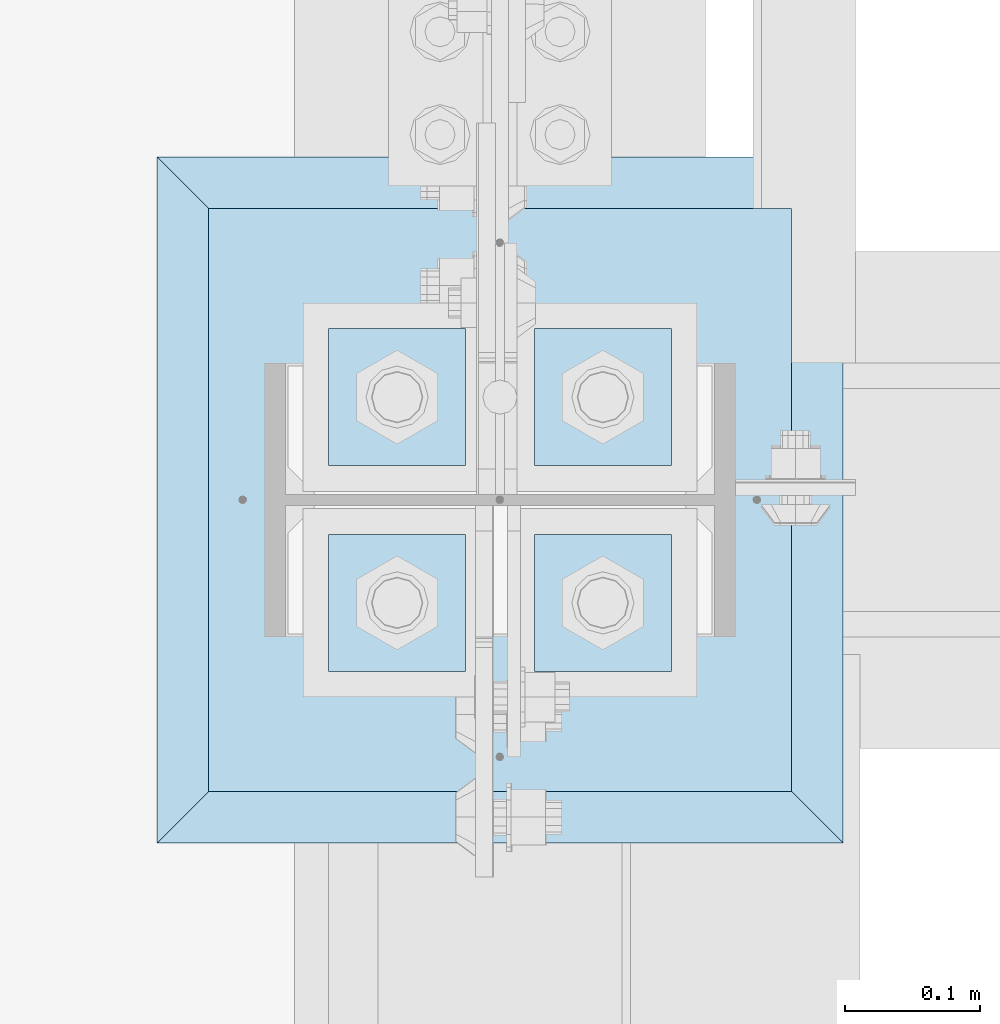
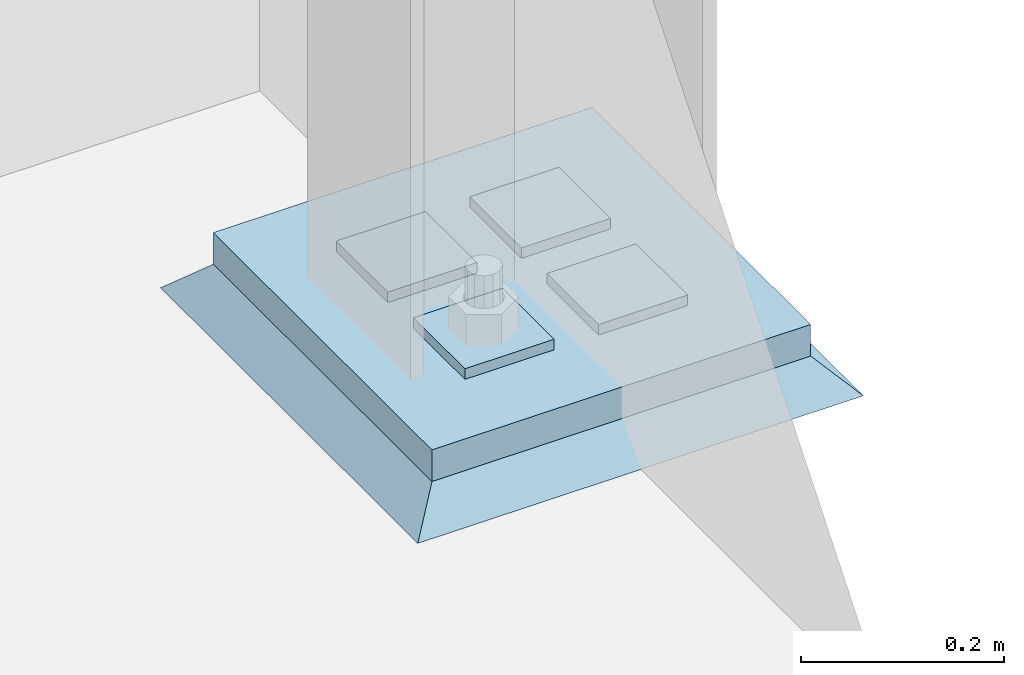
# One storey, part 3505 of 3843: 6 plates, 3 elements without a shape of their own.
"""IFC2X3 building model written with IfcOpenShell, lengths in millimetres."""

import ifcopenshell
import ifcopenshell.guid

model = None  # the IFC model being written
_history = None  # IfcOwnerHistory: only IFC2X3 demands one
_inside = {}  # id of a spatial element -> (the spatial element, [elements in it])
_under = {}  # id of a project, library or spatial element -> (it, [spatial elements below it])
_declared = {}  # id of a project -> (the project, [libraries it declares])
_typed = {}  # id of a type object -> (the type object, [elements of that type])
_made_of = {}  # id of a material, layer set ... -> (it, [elements and type objects made of it])


def new_model(schema):
    """Start an empty IFC model of exactly this schema.

    Asked for "IFC4X3", IfcOpenShell would pick the latest addendum, in which some entities
    have other attributes; the version numbers below select the first issue.
    IFC2X3 requires an IfcOwnerHistory on every rooted entity: one is made here for all.
    """
    global model, _history
    if schema == "IFC4X3":
        model = ifcopenshell.file(schema_version=(4, 3, 0, 0))
    else:
        model = ifcopenshell.file(schema=schema)
    _inside.clear()
    _under.clear()
    _declared.clear()
    _typed.clear()
    _made_of.clear()
    _history = None
    if model.schema == "IFC2X3":
        org = make("IfcOrganization", Name="unknown")
        user = make(
            "IfcPersonAndOrganization",
            ThePerson=make("IfcPerson", FamilyName="unknown"),
            TheOrganization=org,
        )
        app = make(
            "IfcApplication",
            ApplicationDeveloper=org,
            Version="unknown",
            ApplicationFullName="unknown",
            ApplicationIdentifier="unknown",
        )
        _history = make(
            "IfcOwnerHistory",
            OwningUser=user,
            OwningApplication=app,
            ChangeAction="ADDED",
            CreationDate=0,
        )
    return model


def make(cls, **values):
    """One entity of the class cls with the attributes given. An attribute that is None is left unset."""
    return model.create_entity(
        cls, **{name: value for name, value in values.items() if value is not None}
    )


def rooted(cls, **values):
    """An entity with a GlobalId (a new one), such as an element, a storey or a relation."""
    return make(cls, GlobalId=ifcopenshell.guid.new(), OwnerHistory=_history, **values)


def si_unit(unit_type, name, prefix=None):
    """IfcSIUnit, for example si_unit("LENGTHUNIT", "METRE", prefix="MILLI")."""
    return make("IfcSIUnit", UnitType=unit_type, Prefix=prefix, Name=name)


def assignment(units):
    """IfcUnitAssignment: the units of a project."""
    return None if units is None else make("IfcUnitAssignment", Units=units)


def point(xyz):
    """IfcCartesianPoint."""
    return None if xyz is None else make("IfcCartesianPoint", Coordinates=xyz)


def direction(xyz):
    """IfcDirection."""
    return None if xyz is None else make("IfcDirection", DirectionRatios=xyz)


def frame(location, z_axis=None, x_axis=None):
    """IfcAxis2Placement3D, a coordinate frame: its origin and axes. An axis left out is left unset."""
    return make(
        "IfcAxis2Placement3D",
        Location=point(location),
        Axis=direction(z_axis),
        RefDirection=direction(x_axis),
    )


def origin_with_axes():
    """The frame at (0, 0, 0) with the z axis (0, 0, 1) and the x axis (1, 0, 0) written out."""
    return frame((0.0, 0.0, 0.0), z_axis=(0.0, 0.0, 1.0), x_axis=(1.0, 0.0, 0.0))


def place(relative_to, where):
    """IfcLocalPlacement: puts the frame where relative to a parent placement (None: the world)."""
    return make(
        "IfcLocalPlacement", PlacementRelTo=relative_to, RelativePlacement=where
    )


def context(
    kind, dimensions, precision=None, world=None, true_north=None, identifier=None
):
    """IfcGeometricRepresentationContext, for example the 3D "Model" context."""
    return make(
        "IfcGeometricRepresentationContext",
        ContextIdentifier=identifier,
        ContextType=kind,
        CoordinateSpaceDimension=dimensions,
        Precision=precision,
        WorldCoordinateSystem=world,
        TrueNorth=true_north,
    )


def subcontext(parent, identifier, kind, view, scale=None):
    """IfcGeometricRepresentationSubContext, for example "Body" below "Model"."""
    return make(
        "IfcGeometricRepresentationSubContext",
        ContextIdentifier=identifier,
        ContextType=kind,
        ParentContext=parent,
        TargetScale=scale,
        TargetView=view,
    )


def project(units=None, contexts=None):
    """IfcProject with its units and contexts."""
    return rooted(
        "IfcProject",
        Name="project",
        RepresentationContexts=contexts,
        UnitsInContext=assignment(units),
    )


def spatial(cls, under=None, at=None, **own):
    """A site, building, storey or space (cls), placed at a placement, below another one or the project."""
    s = rooted(cls, ObjectPlacement=at, **own)
    if under is not None:
        _under.setdefault(under.id(), (under, []))[1].append(s)
    return s


def faces_of(points, faces, orient=None, outer=None):
    """IfcFace entities. A face is a list of loops; a loop is a list of indices into points, from 0.

    orient and outer hold one flag for each loop. By default every Orientation is true, the
    first loop of a face is its IfcFaceOuterBound and the others are IfcFaceBound.
    """
    made = []
    for i, loops in enumerate(faces):
        bounds = []
        for j, loop in enumerate(loops):
            is_outer = j == 0 if outer is None else outer[i][j]
            bounds.append(
                make(
                    "IfcFaceOuterBound" if is_outer else "IfcFaceBound",
                    Bound=make("IfcPolyLoop", Polygon=[points[k] for k in loop]),
                    Orientation=True if orient is None else orient[i][j],
                )
            )
        made.append(make("IfcFace", Bounds=bounds))
    return made


def faceted_brep(points, faces, orient=None, outer=None, voids=None):
    """IfcFacetedBrep: a solid bounded by flat faces; with voids (closed shells), ...WithVoids."""
    shared = [point(p) for p in points]
    hull = make("IfcClosedShell", CfsFaces=faces_of(shared, faces, orient, outer))
    if voids is None:
        return make("IfcFacetedBrep", Outer=hull)
    return make(
        "IfcFacetedBrepWithVoids",
        Outer=hull,
        Voids=[
            make(cls, CfsFaces=faces_of(shared, fs, o, b)) for cls, fs, o, b in voids
        ],
    )


def shape(context_of_items, identifier, shape_type, items):
    """IfcShapeRepresentation: the items that make up one representation, for example the "Body"."""
    return make(
        "IfcShapeRepresentation",
        ContextOfItems=context_of_items,
        RepresentationIdentifier=identifier,
        RepresentationType=shape_type,
        Items=items,
    )


def material(Name=None, Category=None):
    """IfcMaterial."""
    return make("IfcMaterial", Name=Name, Category=Category)


def made_of(thing, what):
    """Note that an element or type object is made of a material, layer set ...; save() writes the relation."""
    if what is not None:
        _made_of.setdefault(what.id(), (what, []))[1].append(thing)
    return thing


def type_object(cls, material=None, **own):
    """A type object (cls), such as IfcWallType, which elements share."""
    return made_of(rooted(cls, **own), material)


def element(
    cls,
    number,
    at=None,
    inside=None,
    cuts=None,
    type_object=None,
    material=None,
    context=None,
    identifier="Body",
    shape_type=None,
    held_by="IfcProductDefinitionShape",
    body=None,
    shapes=None,
    **own,
):
    """One element of the class cls, such as IfcWall. Its Tag is "e" and its number.

    at: its placement. inside: the storey or other place that contains it. cuts: it is an
    opening in that element (IfcRelVoidsElement). A single representation is given by context,
    identifier, shape_type and body (its items); several are given by shapes. held_by: the class
    of the entity that holds the representations. save() writes the other relations.
    """
    e = rooted(cls, Tag="e%d" % number, ObjectPlacement=at, **own)
    if body is not None:
        shapes = [shape(context, identifier, shape_type, body)]
    if shapes is not None:
        e.Representation = make(held_by, Representations=shapes)
    if inside is not None:
        _inside.setdefault(inside.id(), (inside, []))[1].append(e)
    if cuts is not None:
        rooted(
            "IfcRelVoidsElement", RelatingBuildingElement=cuts, RelatedOpeningElement=e
        )
    if type_object is not None:
        _typed.setdefault(type_object.id(), (type_object, []))[1].append(e)
    return made_of(e, material)


def aggregate(whole, parts):
    """IfcRelAggregates: a whole, such as a stair, and the parts it consists of."""
    return rooted("IfcRelAggregates", RelatingObject=whole, RelatedObjects=parts)


def save(model, path):
    """Write the relations noted so far, then the file.

    IfcRelAggregates (storeys below a building ...), IfcRelContainedInSpatialStructure (elements
    in a storey), IfcRelDefinesByType, IfcRelAssociatesMaterial and IfcRelDeclares: one each for
    every whole, place, type object, material and project.
    """
    for whole, parts in _under.values():
        aggregate(whole, parts)
    for where, things in _inside.values():
        rooted(
            "IfcRelContainedInSpatialStructure",
            RelatedElements=things,
            RelatingStructure=where,
        )
    for kind, things in _typed.values():
        rooted("IfcRelDefinesByType", RelatedObjects=things, RelatingType=kind)
    for what, things in _made_of.values():
        rooted("IfcRelAssociatesMaterial", RelatedObjects=things, RelatingMaterial=what)
    for by, libraries in _declared.values():
        rooted("IfcRelDeclares", RelatingContext=by, RelatedDefinitions=libraries)
    model.write(path)


model = new_model("IFC2X3")

# Units and contexts
model_context = context("Model", 3, precision=1e-05, world=origin_with_axes())
body_context = subcontext(model_context, "Body", "Model", "MODEL_VIEW")
ifc_project = project(units=[si_unit("LENGTHUNIT", "METRE", prefix="MILLI"), si_unit("AREAUNIT", "SQUARE_METRE"), si_unit("VOLUMEUNIT", "CUBIC_METRE"), si_unit("MASSUNIT", "GRAM", prefix="KILO"), si_unit("TIMEUNIT", "SECOND"), si_unit("PLANEANGLEUNIT", "RADIAN"), si_unit("SOLIDANGLEUNIT", "STERADIAN"), si_unit("THERMODYNAMICTEMPERATUREUNIT", "DEGREE_CELSIUS"), si_unit("LUMINOUSINTENSITYUNIT", "LUMEN")], contexts=[model_context])

# Site, building, storey
site_placement = place(None, origin_with_axes())
site = spatial("IfcSite", under=ifc_project, at=site_placement, CompositionType="ELEMENT")
building_placement = place(site_placement, origin_with_axes())
building = spatial("IfcBuilding", under=site, at=building_placement, Name="Undefined", CompositionType="ELEMENT")
storey_placement = place(building_placement, origin_with_axes())
storey = spatial("IfcBuildingStorey", under=building, at=storey_placement, Name="Undefined", CompositionType="ELEMENT", Elevation=0.0)

# Assembly, plates
assembly_1_placement = place(storey_placement, origin_with_axes())
assembly_1 = element("IfcElementAssembly", 1, at=assembly_1_placement, inside=storey, Name="TEMPLATE", AssemblyPlace="NOTDEFINED", PredefinedType="RIGID_FRAME")
ifc_material_1 = material(Name="STEEL/A572-50")
plate_type_1 = type_object("IfcPlateType", PredefinedType="NOTDEFINED")
plate_1_placement = place(assembly_1_placement, frame((77038.2, 89090.5, 29648.15), z_axis=(0.0, -1.0, 0.0), x_axis=(1.0, 0.0, 0.0)))
plate_1 = element("IfcPlate", 2, at=plate_1_placement, type_object=plate_type_1, material=ifc_material_1, Name="Washer Plate", context=body_context, shape_type="Brep", body=[
    faceted_brep([(0.0, -6.3499999046162, 0.0), (-1.67347025126219e-10, -6.35000000000582, 101.600000000151), (-1.67347025126219e-10, 6.35000000000582, 101.600000000151), (7.27595761418343e-12, 6.3499999046162, 0.0), (101.599998474121, -6.34999999999854, 101.599998474121), (101.599998474121, 6.34999999999854, 101.599998474121), (101.6, -6.34999999999854, 0.0), (101.6, 6.34999999999854, 0.0)], [[[0, 1, 2, 3]], [[1, 4, 5, 2]], [[4, 6, 7, 5]], [[6, 0, 3, 7]], [[5, 7, 3, 2]], [[6, 4, 1, 0]]]),
])
plate_2_placement = place(assembly_1_placement, frame((77038.2, 89242.9, 29648.15), z_axis=(0.0, -1.0, 0.0), x_axis=(1.0, 0.0, 0.0)))
plate_2 = element("IfcPlate", 3, at=plate_2_placement, type_object=plate_type_1, material=ifc_material_1, Name="Washer Plate", context=body_context, shape_type="Brep", body=[
    faceted_brep([(0.0, -6.3499999046162, 0.0), (-1.67347025126219e-10, -6.35000000000582, 101.600000000151), (-1.67347025126219e-10, 6.35000000000582, 101.600000000151), (7.27595761418343e-12, 6.3499999046162, 0.0), (101.599998474121, -6.34999999999854, 101.599998474121), (101.599998474121, 6.34999999999854, 101.599998474121), (101.6, -6.34999999999854, 0.0), (101.6, 6.34999999999854, 0.0)], [[[0, 1, 2, 3]], [[1, 4, 5, 2]], [[4, 6, 7, 5]], [[6, 0, 3, 7]], [[5, 7, 3, 2]], [[6, 4, 1, 0]]]),
])
plate_3_placement = place(assembly_1_placement, frame((76885.8, 89090.5, 29648.15), z_axis=(0.0, -1.0, 0.0), x_axis=(1.0, 0.0, 0.0)))
plate_3 = element("IfcPlate", 4, at=plate_3_placement, type_object=plate_type_1, material=ifc_material_1, Name="Washer Plate", context=body_context, shape_type="Brep", body=[
    faceted_brep([(0.0, -6.3499999046162, 0.0), (-1.67347025126219e-10, -6.35000000000582, 101.600000000151), (-1.67347025126219e-10, 6.35000000000582, 101.600000000151), (7.27595761418343e-12, 6.3499999046162, 0.0), (101.599998474121, -6.34999999999854, 101.599998474121), (101.599998474121, 6.34999999999854, 101.599998474121), (101.6, -6.34999999999854, 0.0), (101.6, 6.34999999999854, 0.0)], [[[0, 1, 2, 3]], [[1, 4, 5, 2]], [[4, 6, 7, 5]], [[6, 0, 3, 7]], [[5, 7, 3, 2]], [[6, 4, 1, 0]]]),
])
plate_4_placement = place(assembly_1_placement, frame((76885.8, 89242.9, 29648.15), z_axis=(0.0, -1.0, 0.0), x_axis=(1.0, 0.0, 0.0)))
plate_4 = element("IfcPlate", 5, at=plate_4_placement, type_object=plate_type_1, material=ifc_material_1, Name="Washer Plate", context=body_context, shape_type="Brep", body=[
    faceted_brep([(0.0, -6.3499999046162, 0.0), (-1.67347025126219e-10, -6.35000000000582, 101.600000000151), (-1.67347025126219e-10, 6.35000000000582, 101.600000000151), (7.27595761418343e-12, 6.3499999046162, 0.0), (101.599998474121, -6.34999999999854, 101.599998474121), (101.599998474121, 6.34999999999854, 101.599998474121), (101.6, -6.34999999999854, 0.0), (101.6, 6.34999999999854, 0.0)], [[[0, 1, 2, 3]], [[1, 4, 5, 2]], [[4, 6, 7, 5]], [[6, 0, 3, 7]], [[5, 7, 3, 2]], [[6, 4, 1, 0]]]),
])
aggregate(assembly_1, [plate_1, plate_2, plate_3, plate_4])

# Assembly, plate
assembly_2_placement = place(storey_placement, origin_with_axes())
assembly_2 = element("IfcElementAssembly", 6, at=assembly_2_placement, inside=storey, Name="COLUMN", AssemblyPlace="NOTDEFINED", PredefinedType="RIGID_FRAME")
plate_type_2 = type_object("IfcPlateType", PredefinedType="NOTDEFINED")
plate_5_placement = place(assembly_2_placement, frame((76796.9, 88900.0, 29622.75), z_axis=(0.0, 1.0, 0.0), x_axis=(1.0, 0.0, 0.0)))
plate_5 = element("IfcPlate", 7, at=plate_5_placement, type_object=plate_type_2, material=ifc_material_1, Name="PLATE", context=body_context, shape_type="Brep", body=[
    faceted_brep([(0.0, -19.0500000000029, 0.0), (0.0, -19.0499999999993, 431.799987792969), (0.0, 19.0499999999993, 431.799987792969), (0.0, 19.0500000000029, 0.0), (431.799987792969, -19.0499999999993, 431.799987792969), (431.799987792969, 19.0499999999993, 431.799987792969), (431.799957275391, -19.0499999999993, 0.0), (431.799957275391, 19.0499999999993, 0.0)], [[[0, 1, 2, 3]], [[1, 4, 5, 2]], [[4, 6, 7, 5]], [[6, 0, 3, 7]], [[5, 7, 3, 2]], [[6, 4, 1, 0]]]),
])
aggregate(assembly_2, [plate_5])

assembly_3_placement = place(storey_placement, origin_with_axes())
assembly_3 = element("IfcElementAssembly", 8, at=assembly_3_placement, inside=storey, Name="GROUT", AssemblyPlace="NOTDEFINED", PredefinedType="REINFORCEMENT_UNIT")
ifc_material_2 = material(Name="CONCRETE/Concrete_Undefined")
plate_type_3 = type_object("IfcPlateType", PredefinedType="NOTDEFINED")
plate_6_placement = place(assembly_3_placement, frame((76758.8, 88861.9, 29584.65), z_axis=(0.0, 1.0, 0.0), x_axis=(1.0, 0.0, 0.0)))
plate_6 = element("IfcPlate", 9, at=plate_6_placement, type_object=plate_type_3, material=ifc_material_2, Name="GROUT", context=body_context, shape_type="Brep", body=[
    faceted_brep([(38.1000000007043, -19.0499999997883, 469.899999999314), (0.0, 19.0499999999993, 508.0), (0.0, 19.0500000000029, 0.0), (38.1000000006916, -19.0499999999811, 38.1000000006607), (469.899999999325, -19.0499999998174, 38.1000000006607), (508.0, 19.0499999999993, 0.0), (508.0, 19.0499999999993, 508.0), (469.899999999325, -19.0499999999847, 469.899999999314)], [[[0, 1, 2, 3]], [[4, 5, 6, 7]], [[4, 7, 0, 3]], [[5, 4, 3, 2]], [[6, 5, 2, 1]], [[7, 6, 1, 0]]]),
])
aggregate(assembly_3, [plate_6])

save(model, "model.ifc")
